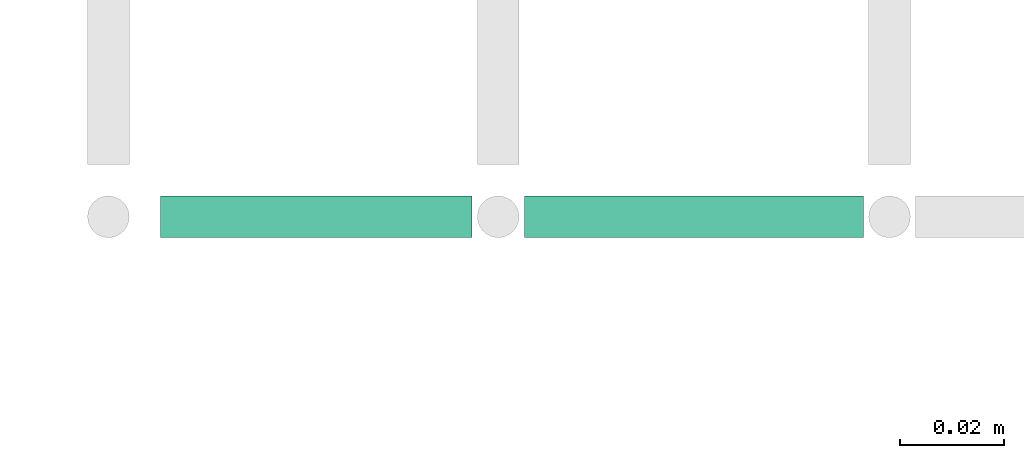
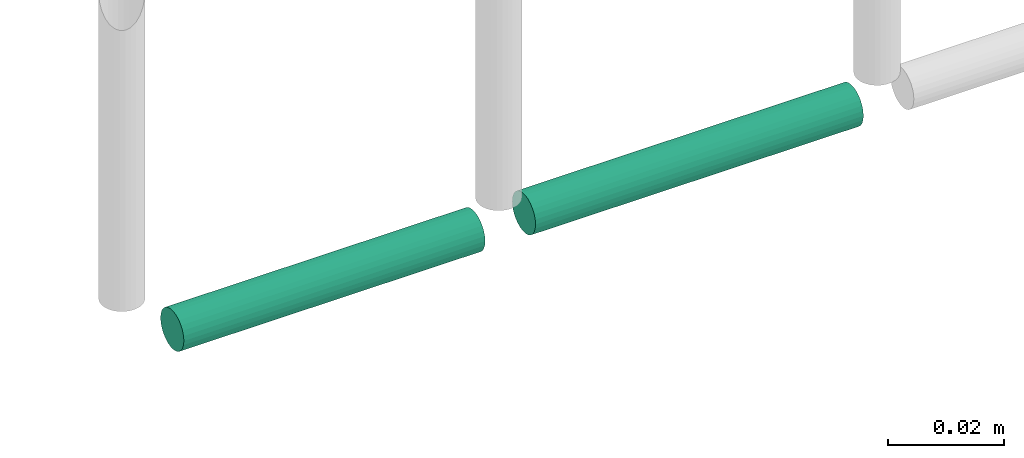
# One storey, part 318 of 331: 2 flow segments.
"""IFC2X3 building model written with IfcOpenShell, lengths in millimetres."""

from ifc_helpers import new_model, entity, si_unit, converted_unit, derived_unit, direction, frame, frame_2d, origin, origin_2d_with_axis, place, context, subcontext, project, spatial, circle, extrude, type_object, element, save


model = new_model("IFC2X3")

# Units and contexts
model_context = context("Model", 3, precision=0.01, world=origin(), true_north=direction((6.12303176911189e-17, 1.0)))
body_context = subcontext(model_context, "Body", "Model", "MODEL_VIEW")
ifc_project = project(units=[si_unit("LENGTHUNIT", "METRE", prefix="MILLI"), si_unit("AREAUNIT", "SQUARE_METRE"), si_unit("VOLUMEUNIT", "CUBIC_METRE"), converted_unit("PLANEANGLEUNIT", "DEGREE", entity("IfcRatioMeasure", 0.0174532925199433), si_unit("PLANEANGLEUNIT", "RADIAN"), dimensions=[0, 0, 0, 0, 0, 0, 0]), si_unit("MASSUNIT", "GRAM", prefix="KILO"), derived_unit("MASSDENSITYUNIT", [(si_unit("MASSUNIT", "GRAM", prefix="KILO"), 1), (si_unit("LENGTHUNIT", "METRE"), -3)]), derived_unit("MOMENTOFINERTIAUNIT", [(si_unit("LENGTHUNIT", "METRE"), 4)]), si_unit("TIMEUNIT", "SECOND"), si_unit("FREQUENCYUNIT", "HERTZ"), si_unit("THERMODYNAMICTEMPERATUREUNIT", "DEGREE_CELSIUS"), derived_unit("THERMALTRANSMITTANCEUNIT", [(si_unit("MASSUNIT", "GRAM", prefix="KILO"), 1), (si_unit("THERMODYNAMICTEMPERATUREUNIT", "KELVIN"), -1), (si_unit("TIMEUNIT", "SECOND"), -3)]), derived_unit("VOLUMETRICFLOWRATEUNIT", [(si_unit("LENGTHUNIT", "METRE"), 3), (si_unit("TIMEUNIT", "SECOND"), -1)]), derived_unit("MASSFLOWRATEUNIT", [(si_unit("MASSUNIT", "GRAM", prefix="KILO"), 1), (si_unit("TIMEUNIT", "SECOND"), -1)]), derived_unit("ROTATIONALFREQUENCYUNIT", [(si_unit("TIMEUNIT", "SECOND"), -1)]), si_unit("ELECTRICCURRENTUNIT", "AMPERE"), si_unit("ELECTRICVOLTAGEUNIT", "VOLT"), si_unit("POWERUNIT", "WATT"), si_unit("FORCEUNIT", "NEWTON", prefix="KILO"), si_unit("ILLUMINANCEUNIT", "LUX"), si_unit("LUMINOUSFLUXUNIT", "LUMEN"), si_unit("LUMINOUSINTENSITYUNIT", "CANDELA"), derived_unit("USERDEFINED", [(si_unit("MASSUNIT", "GRAM", prefix="KILO"), -1), (si_unit("LENGTHUNIT", "METRE"), -2), (si_unit("TIMEUNIT", "SECOND"), 3), (si_unit("LUMINOUSFLUXUNIT", "LUMEN"), 1)]), derived_unit("LINEARVELOCITYUNIT", [(si_unit("LENGTHUNIT", "METRE"), 1), (si_unit("TIMEUNIT", "SECOND"), -1)]), si_unit("PRESSUREUNIT", "PASCAL"), derived_unit("USERDEFINED", [(si_unit("LENGTHUNIT", "METRE"), -2), (si_unit("MASSUNIT", "GRAM", prefix="KILO"), 1), (si_unit("TIMEUNIT", "SECOND"), -2)]), derived_unit("LINEARFORCEUNIT", [(si_unit("MASSUNIT", "GRAM", prefix="KILO"), 1), (si_unit("LENGTHUNIT", "METRE"), 1), (si_unit("TIMEUNIT", "SECOND"), -2), (si_unit("LENGTHUNIT", "METRE"), -1)]), derived_unit("PLANARFORCEUNIT", [(si_unit("MASSUNIT", "GRAM", prefix="KILO"), 1), (si_unit("LENGTHUNIT", "METRE"), 1), (si_unit("TIMEUNIT", "SECOND"), -2), (si_unit("LENGTHUNIT", "METRE"), -2)])], contexts=[model_context])

# Site, building, storey
site_placement = place(None, frame((0.0, -0.00077364408347762, 0.0)))
site = spatial("IfcSite", under=ifc_project, at=site_placement, CompositionType="ELEMENT")
building_placement = place(site_placement, origin())
building = spatial("IfcBuilding", under=site, at=building_placement, CompositionType="ELEMENT")
storey_placement = place(building_placement, origin())
storey = spatial("IfcBuildingStorey", under=building, at=storey_placement, CompositionType="ELEMENT", Elevation=0.0)

# Flow segments
pipe_segment_type = type_object("IfcPipeSegmentType", PredefinedType="NOTDEFINED")
flow_segment_1_placement = place(building_placement, frame((59893.4325677238, 16292.9115686368, 6669.40472776409)))
element("IfcFlowSegment", 1, at=flow_segment_1_placement, inside=storey, type_object=pipe_segment_type, context=body_context, shape_type="SweptSolid", body=[
    extrude(circle(Radius=4.0, at=frame_2d((-1.08286712929839e-11, 0.0), x_axis=(1.0, 0.0))), frame((0.0, 5.59527223592582, 5.59527223591607), z_axis=(1.0, 0.0, 0.0), x_axis=(0.0, 1.0, 0.0)), (0.0, 0.0, 1.0), 59.7146023569135),
])
flow_segment_2_placement = place(building_placement, frame((59963.1471700807, 16292.9115686369, 6669.40472776408)))
element("IfcFlowSegment", 2, at=flow_segment_2_placement, inside=storey, type_object=pipe_segment_type, context=body_context, shape_type="SweptSolid", body=[
    extrude(circle(Radius=4.0, at=origin_2d_with_axis()), frame((0.0, 5.59527223591499, 5.59527223591607), z_axis=(1.0, 0.0, 0.0), x_axis=(0.0, 1.0, 0.0)), (0.0, 0.0, 1.0), 65.0000000000025),
])

save(model, "model.ifc")
